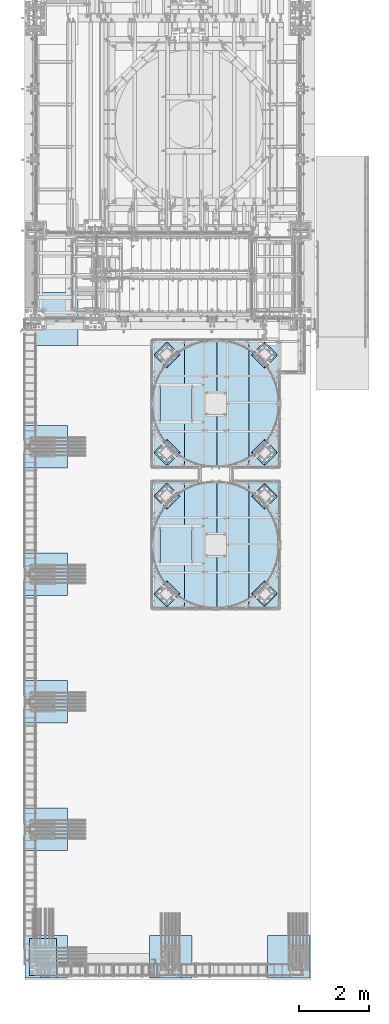
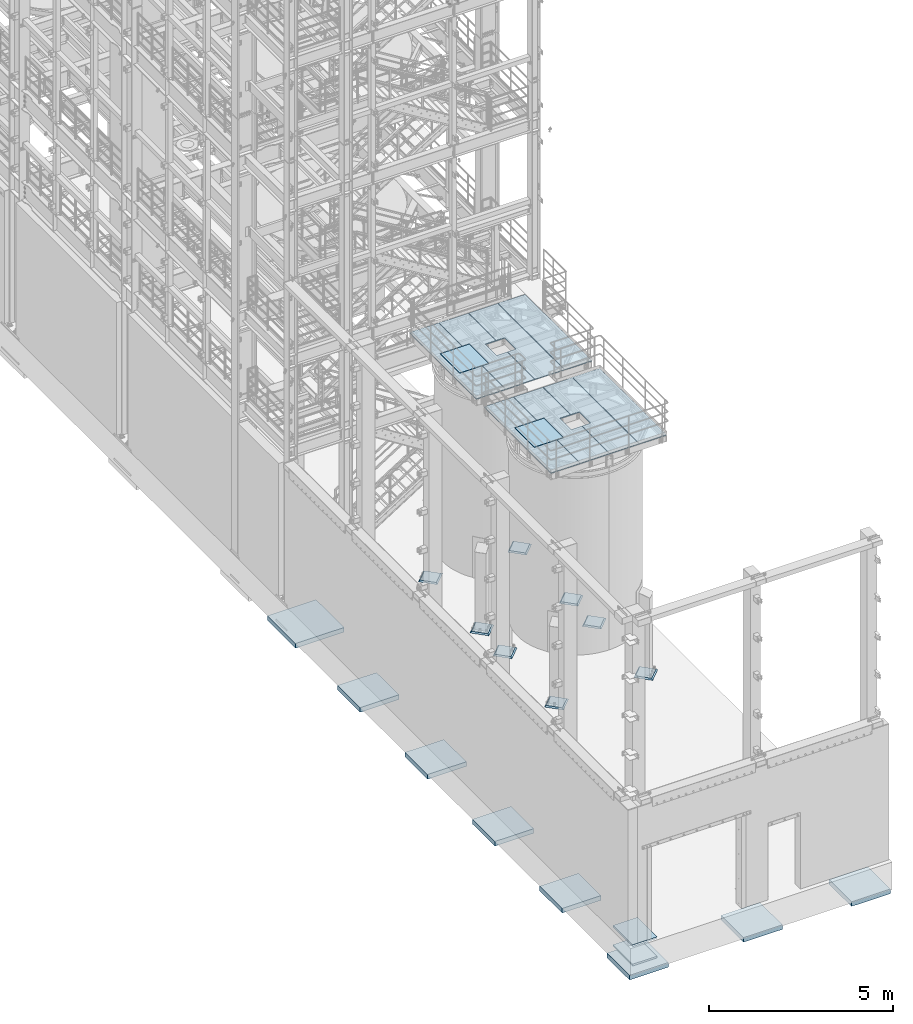
# One storey, part 1401 of 1876: 20 plates, 8 slabs, 27 elements without a shape of their own.
"""IFC2X3 building model written with IfcOpenShell, lengths in millimetres."""

import ifcopenshell
import ifcopenshell.guid

model = None  # the IFC model being written
_history = None  # IfcOwnerHistory: only IFC2X3 demands one
_inside = {}  # id of a spatial element -> (the spatial element, [elements in it])
_under = {}  # id of a project, library or spatial element -> (it, [spatial elements below it])
_declared = {}  # id of a project -> (the project, [libraries it declares])
_typed = {}  # id of a type object -> (the type object, [elements of that type])
_made_of = {}  # id of a material, layer set ... -> (it, [elements and type objects made of it])


def new_model(schema):
    """Start an empty IFC model of exactly this schema.

    Asked for "IFC4X3", IfcOpenShell would pick the latest addendum, in which some entities
    have other attributes; the version numbers below select the first issue.
    IFC2X3 requires an IfcOwnerHistory on every rooted entity: one is made here for all.
    """
    global model, _history
    if schema == "IFC4X3":
        model = ifcopenshell.file(schema_version=(4, 3, 0, 0))
    else:
        model = ifcopenshell.file(schema=schema)
    _inside.clear()
    _under.clear()
    _declared.clear()
    _typed.clear()
    _made_of.clear()
    _history = None
    if model.schema == "IFC2X3":
        org = make("IfcOrganization", Name="unknown")
        user = make(
            "IfcPersonAndOrganization",
            ThePerson=make("IfcPerson", FamilyName="unknown"),
            TheOrganization=org,
        )
        app = make(
            "IfcApplication",
            ApplicationDeveloper=org,
            Version="unknown",
            ApplicationFullName="unknown",
            ApplicationIdentifier="unknown",
        )
        _history = make(
            "IfcOwnerHistory",
            OwningUser=user,
            OwningApplication=app,
            ChangeAction="ADDED",
            CreationDate=0,
        )
    return model


def make(cls, **values):
    """One entity of the class cls with the attributes given. An attribute that is None is left unset."""
    return model.create_entity(
        cls, **{name: value for name, value in values.items() if value is not None}
    )


def rooted(cls, **values):
    """An entity with a GlobalId (a new one), such as an element, a storey or a relation."""
    return make(cls, GlobalId=ifcopenshell.guid.new(), OwnerHistory=_history, **values)


def si_unit(unit_type, name, prefix=None):
    """IfcSIUnit, for example si_unit("LENGTHUNIT", "METRE", prefix="MILLI")."""
    return make("IfcSIUnit", UnitType=unit_type, Prefix=prefix, Name=name)


def assignment(units):
    """IfcUnitAssignment: the units of a project."""
    return None if units is None else make("IfcUnitAssignment", Units=units)


def point(xyz):
    """IfcCartesianPoint."""
    return None if xyz is None else make("IfcCartesianPoint", Coordinates=xyz)


def direction(xyz):
    """IfcDirection."""
    return None if xyz is None else make("IfcDirection", DirectionRatios=xyz)


def frame(location, z_axis=None, x_axis=None):
    """IfcAxis2Placement3D, a coordinate frame: its origin and axes. An axis left out is left unset."""
    return make(
        "IfcAxis2Placement3D",
        Location=point(location),
        Axis=direction(z_axis),
        RefDirection=direction(x_axis),
    )


def origin_with_axes():
    """The frame at (0, 0, 0) with the z axis (0, 0, 1) and the x axis (1, 0, 0) written out."""
    return frame((0.0, 0.0, 0.0), z_axis=(0.0, 0.0, 1.0), x_axis=(1.0, 0.0, 0.0))


def place(relative_to, where):
    """IfcLocalPlacement: puts the frame where relative to a parent placement (None: the world)."""
    return make(
        "IfcLocalPlacement", PlacementRelTo=relative_to, RelativePlacement=where
    )


def context(
    kind, dimensions, precision=None, world=None, true_north=None, identifier=None
):
    """IfcGeometricRepresentationContext, for example the 3D "Model" context."""
    return make(
        "IfcGeometricRepresentationContext",
        ContextIdentifier=identifier,
        ContextType=kind,
        CoordinateSpaceDimension=dimensions,
        Precision=precision,
        WorldCoordinateSystem=world,
        TrueNorth=true_north,
    )


def subcontext(parent, identifier, kind, view, scale=None):
    """IfcGeometricRepresentationSubContext, for example "Body" below "Model"."""
    return make(
        "IfcGeometricRepresentationSubContext",
        ContextIdentifier=identifier,
        ContextType=kind,
        ParentContext=parent,
        TargetScale=scale,
        TargetView=view,
    )


def project(units=None, contexts=None):
    """IfcProject with its units and contexts."""
    return rooted(
        "IfcProject",
        Name="project",
        RepresentationContexts=contexts,
        UnitsInContext=assignment(units),
    )


def spatial(cls, under=None, at=None, **own):
    """A site, building, storey or space (cls), placed at a placement, below another one or the project."""
    s = rooted(cls, ObjectPlacement=at, **own)
    if under is not None:
        _under.setdefault(under.id(), (under, []))[1].append(s)
    return s


def faces_of(points, faces, orient=None, outer=None):
    """IfcFace entities. A face is a list of loops; a loop is a list of indices into points, from 0.

    orient and outer hold one flag for each loop. By default every Orientation is true, the
    first loop of a face is its IfcFaceOuterBound and the others are IfcFaceBound.
    """
    made = []
    for i, loops in enumerate(faces):
        bounds = []
        for j, loop in enumerate(loops):
            is_outer = j == 0 if outer is None else outer[i][j]
            bounds.append(
                make(
                    "IfcFaceOuterBound" if is_outer else "IfcFaceBound",
                    Bound=make("IfcPolyLoop", Polygon=[points[k] for k in loop]),
                    Orientation=True if orient is None else orient[i][j],
                )
            )
        made.append(make("IfcFace", Bounds=bounds))
    return made


def faceted_brep(points, faces, orient=None, outer=None, voids=None):
    """IfcFacetedBrep: a solid bounded by flat faces; with voids (closed shells), ...WithVoids."""
    shared = [point(p) for p in points]
    hull = make("IfcClosedShell", CfsFaces=faces_of(shared, faces, orient, outer))
    if voids is None:
        return make("IfcFacetedBrep", Outer=hull)
    return make(
        "IfcFacetedBrepWithVoids",
        Outer=hull,
        Voids=[
            make(cls, CfsFaces=faces_of(shared, fs, o, b)) for cls, fs, o, b in voids
        ],
    )


def shape(context_of_items, identifier, shape_type, items):
    """IfcShapeRepresentation: the items that make up one representation, for example the "Body"."""
    return make(
        "IfcShapeRepresentation",
        ContextOfItems=context_of_items,
        RepresentationIdentifier=identifier,
        RepresentationType=shape_type,
        Items=items,
    )


def material(Name=None, Category=None):
    """IfcMaterial."""
    return make("IfcMaterial", Name=Name, Category=Category)


def made_of(thing, what):
    """Note that an element or type object is made of a material, layer set ...; save() writes the relation."""
    if what is not None:
        _made_of.setdefault(what.id(), (what, []))[1].append(thing)
    return thing


def type_object(cls, material=None, **own):
    """A type object (cls), such as IfcWallType, which elements share."""
    return made_of(rooted(cls, **own), material)


def element(
    cls,
    number,
    at=None,
    inside=None,
    cuts=None,
    type_object=None,
    material=None,
    context=None,
    identifier="Body",
    shape_type=None,
    held_by="IfcProductDefinitionShape",
    body=None,
    shapes=None,
    **own,
):
    """One element of the class cls, such as IfcWall. Its Tag is "e" and its number.

    at: its placement. inside: the storey or other place that contains it. cuts: it is an
    opening in that element (IfcRelVoidsElement). A single representation is given by context,
    identifier, shape_type and body (its items); several are given by shapes. held_by: the class
    of the entity that holds the representations. save() writes the other relations.
    """
    e = rooted(cls, Tag="e%d" % number, ObjectPlacement=at, **own)
    if body is not None:
        shapes = [shape(context, identifier, shape_type, body)]
    if shapes is not None:
        e.Representation = make(held_by, Representations=shapes)
    if inside is not None:
        _inside.setdefault(inside.id(), (inside, []))[1].append(e)
    if cuts is not None:
        rooted(
            "IfcRelVoidsElement", RelatingBuildingElement=cuts, RelatedOpeningElement=e
        )
    if type_object is not None:
        _typed.setdefault(type_object.id(), (type_object, []))[1].append(e)
    return made_of(e, material)


def aggregate(whole, parts):
    """IfcRelAggregates: a whole, such as a stair, and the parts it consists of."""
    return rooted("IfcRelAggregates", RelatingObject=whole, RelatedObjects=parts)


def save(model, path):
    """Write the relations noted so far, then the file.

    IfcRelAggregates (storeys below a building ...), IfcRelContainedInSpatialStructure (elements
    in a storey), IfcRelDefinesByType, IfcRelAssociatesMaterial and IfcRelDeclares: one each for
    every whole, place, type object, material and project.
    """
    for whole, parts in _under.values():
        aggregate(whole, parts)
    for where, things in _inside.values():
        rooted(
            "IfcRelContainedInSpatialStructure",
            RelatedElements=things,
            RelatingStructure=where,
        )
    for kind, things in _typed.values():
        rooted("IfcRelDefinesByType", RelatedObjects=things, RelatingType=kind)
    for what, things in _made_of.values():
        rooted("IfcRelAssociatesMaterial", RelatedObjects=things, RelatingMaterial=what)
    for by, libraries in _declared.values():
        rooted("IfcRelDeclares", RelatingContext=by, RelatedDefinitions=libraries)
    model.write(path)


model = new_model("IFC2X3")

# Units and contexts
model_context = context("Model", 3, precision=1e-05, world=origin_with_axes())
body_context = subcontext(model_context, "Body", "Model", "MODEL_VIEW")
ifc_project = project(units=[si_unit("LENGTHUNIT", "METRE", prefix="MILLI"), si_unit("AREAUNIT", "SQUARE_METRE"), si_unit("VOLUMEUNIT", "CUBIC_METRE"), si_unit("MASSUNIT", "GRAM", prefix="KILO"), si_unit("TIMEUNIT", "SECOND"), si_unit("PLANEANGLEUNIT", "RADIAN"), si_unit("SOLIDANGLEUNIT", "STERADIAN"), si_unit("THERMODYNAMICTEMPERATUREUNIT", "DEGREE_CELSIUS"), si_unit("LUMINOUSINTENSITYUNIT", "LUMEN")], contexts=[model_context])

# Site, building, storey
site_placement = place(None, origin_with_axes())
site = spatial("IfcSite", under=ifc_project, at=site_placement, CompositionType="ELEMENT")
building_placement = place(site_placement, origin_with_axes())
building = spatial("IfcBuilding", under=site, at=building_placement, Name="Undefined", CompositionType="ELEMENT")
storey_placement = place(building_placement, origin_with_axes())
storey = spatial("IfcBuildingStorey", under=building, at=storey_placement, Name="Undefined", CompositionType="ELEMENT", Elevation=0.0)

# Assembly, plate
assembly_1_placement = place(storey_placement, origin_with_axes())
assembly_1 = element("IfcElementAssembly", 1, at=assembly_1_placement, inside=storey, Name="GRATING", AssemblyPlace="NOTDEFINED", PredefinedType="NOTDEFINED")
ifc_material_1 = material(Name="1")
plate_type_1 = type_object("IfcPlateType", PredefinedType="NOTDEFINED")
plate_1_placement = place(assembly_1_placement, frame((4294.19438669416, -7727.85504150392, 8010.525), z_axis=(1.0, 0.0, 0.0), x_axis=(0.0, -1.0, 0.0)))
plate_1 = element("IfcPlate", 2, at=plate_1_placement, type_object=plate_type_1, material=ifc_material_1, Name="GRATING", context=body_context, shape_type="Brep", body=[
    faceted_brep([(1505.00936279233, -12.6999999999998, 909.637451171875), (1505.00936279233, -12.6999999999998, 582.6103515625), (1505.00936279233, 12.6999999999998, 582.6103515625), (1505.00936279233, 12.6999999999998, 909.637451171875), (2114.60933837827, -12.6999999999998, 582.6103515625), (2114.60933837827, 12.6999999999998, 582.6103515625), (2114.60933837827, -12.6999999999998, 909.637451171875), (2114.60933837827, 12.6999999999998, 909.637451171875), (0.0, -12.6999999999998, 0.0), (0.0, -12.6999999999998, 909.637451171875), (0.0, 12.6999999999998, 909.637451171875), (0.0, 12.6999999999998, 0.0), (1273.23428955075, 12.6999999999998, 0.0), (1273.23428955075, -12.6999999999998, 0.0), (1273.23428955075, 12.6999999999998, 214.310363769531), (1273.23428955075, -12.6999999999998, 214.310363769531), (2346.38431396481, 12.6999999999998, 214.310363769531), (2346.38431396481, -12.6999999999998, 214.310363769531), (2346.38431396481, 12.6999999999998, 0.0), (2346.38431396481, -12.6999999999998, 0.0), (3619.5029296875, 12.6999999999998, 0.0), (3619.5029296875, -12.6999999999998, 0.0), (3619.5029296875, -12.6999999999998, 909.637451171875), (3619.5029296875, 12.6999999999998, 909.637451171875)], [[[0, 1, 2, 3]], [[4, 5, 2, 1]], [[6, 7, 5, 4]], [[8, 9, 10, 11]], [[8, 11, 12, 13]], [[13, 12, 14, 15]], [[15, 14, 16, 17]], [[17, 16, 18, 19]], [[20, 21, 19, 18]], [[22, 21, 20, 23]], [[1, 0, 9, 8, 13, 15, 17, 19, 21, 22, 6, 4]], [[10, 9, 0, 3]], [[23, 20, 18, 16, 14, 12, 11, 10, 3, 2, 5, 7]], [[22, 23, 7, 6]]]),
])
aggregate(assembly_1, [plate_1])

assembly_2_placement = place(storey_placement, origin_with_axes())
assembly_2 = element("IfcElementAssembly", 3, at=assembly_2_placement, inside=storey, Name="GRATING", AssemblyPlace="NOTDEFINED", PredefinedType="NOTDEFINED")
plate_2_placement = place(assembly_2_placement, frame((4502.15642282698, -9007.43935546873, 8010.525), z_axis=(0.0, -1.0, 0.0), x_axis=(-1.0, 0.0, 0.0)))
plate_2 = element("IfcPlate", 4, at=plate_2_placement, type_object=plate_type_1, material=ifc_material_1, Name="GRATING", context=body_context, shape_type="Brep", body=[
    faceted_brep([(0.0, -12.6999999999998, 0.0), (0.0, -12.6999999999998, 1060.45007324219), (0.0, 12.6999999999998, 1060.45007324219), (0.0, 12.6999999999998, 0.0), (909.637512207031, -12.6999999999998, 1060.45007324219), (909.637512207031, 12.6999999999998, 1060.45007324219), (909.637512207031, -12.6999999999998, 0.0), (909.637512207031, 12.6999999999998, 0.0)], [[[0, 1, 2, 3]], [[1, 4, 5, 2]], [[4, 6, 7, 5]], [[6, 0, 3, 7]], [[5, 7, 3, 2]], [[6, 4, 1, 0]]]),
])
aggregate(assembly_2, [plate_2])

assembly_3_placement = place(storey_placement, origin_with_axes())
assembly_3 = element("IfcElementAssembly", 5, at=assembly_3_placement, inside=storey, Name="GRATING", AssemblyPlace="NOTDEFINED", PredefinedType="NOTDEFINED")
plate_3_placement = place(assembly_3_placement, frame((6126.19981080997, -7727.91440629959, 8010.525), z_axis=(0.0, -1.0, 0.0), x_axis=(-1.0, 0.0, 0.0)))
plate_3 = element("IfcPlate", 6, at=plate_3_placement, type_object=plate_type_1, material=ifc_material_1, Name="GRATING", context=body_context, shape_type="Brep", body=[
    faceted_brep([(909.650556084588, -12.6999999999998, 1504.89205319779), (909.650556084588, 12.6999999999998, 1504.89205319779), (639.795063440009, 12.6999999999998, 1504.89205249954), (639.795063440009, -12.6999999999998, 1504.89205249954), (639.795062220694, 12.6999999999998, 2114.54995044876), (639.795062220694, -12.6999999999998, 2114.54995044876), (909.655820145314, -12.6999999999998, 2114.54763165254), (909.655840365745, 12.6999999999998, 2114.54763165237), (909.637512207031, -12.6999999999998, 0.0), (0.0, -12.6999999999998, 0.0), (0.0, 12.6999999999998, 0.0), (909.637512207031, 12.6999999999998, 0.0), (0.0313640496860899, -12.6999999999998, 3619.44360351562), (0.0313640496860899, 12.6999999999998, 3619.44360351562), (909.668884277267, -12.6999999999998, 3619.44360351565), (909.668884277267, 12.6999999999998, 3619.44360351565)], [[[0, 1, 2, 3]], [[3, 2, 4, 5]], [[6, 5, 4, 7]], [[8, 9, 10, 11]], [[9, 12, 13, 10]], [[12, 14, 15, 13]], [[15, 14, 6, 7]], [[2, 1, 11, 10, 13, 15, 7, 4]], [[8, 11, 1, 0]], [[14, 12, 9, 8, 0, 3, 5, 6]]]),
])
aggregate(assembly_3, [plate_3])

assembly_4_placement = place(storey_placement, origin_with_axes())
assembly_4 = element("IfcElementAssembly", 7, at=assembly_4_placement, inside=storey, Name="GRATING", AssemblyPlace="NOTDEFINED", PredefinedType="NOTDEFINED")
plate_4_placement = place(assembly_4_placement, frame((4281.49144479963, -7727.85498046876, 8010.525), z_axis=(0.0, -1.0, 0.0), x_axis=(-1.0, 0.0, 0.0)))
plate_4 = element("IfcPlate", 8, at=plate_4_placement, type_object=plate_type_1, material=ifc_material_1, Name="GRATING", context=body_context, shape_type="Brep", body=[
    faceted_brep([(700.086669921875, -12.6999999999998, 1273.17810058594), (700.086669921875, 12.6999999999998, 1273.17810058594), (-6.09361450187862e-11, 12.6999999999998, 1273.17810058594), (-6.09361450187862e-11, -12.6999999999998, 1273.17810058594), (700.086669921875, -12.6999999999998, 2346.32873535156), (700.086669921875, 12.6999999999998, 2346.32873535156), (-1.12777343019843e-10, -12.6999999999998, 2346.32873535156), (-1.12777343019843e-10, 12.6999999999998, 2346.32873535156), (-1.73713488038629e-10, -12.6999999999998, 3619.5029296875), (909.637451171875, -12.6999999999998, 3619.5029296875), (909.637451171875, 12.6999999999998, 3619.5029296875), (-1.73713488038629e-10, 12.6999999999998, 3619.5029296875), (909.606201171875, -12.6999999999998, 0.0), (909.606201171875, 12.6999999999998, 0.0), (0.0, -12.6999999999998, 0.0), (0.0, 12.6999999999998, 0.0)], [[[0, 1, 2, 3]], [[4, 5, 1, 0]], [[6, 7, 5, 4]], [[8, 9, 10, 11]], [[9, 12, 13, 10]], [[12, 14, 15, 13]], [[15, 14, 3, 2]], [[11, 10, 13, 15, 2, 1, 5, 7]], [[8, 11, 7, 6]], [[3, 14, 12, 9, 8, 6, 4, 0]]]),
])
aggregate(assembly_4, [plate_4])

assembly_5_placement = place(storey_placement, origin_with_axes())
assembly_5 = element("IfcElementAssembly", 9, at=assembly_5_placement, inside=storey, Name="GRATING", AssemblyPlace="NOTDEFINED", PredefinedType="NOTDEFINED")
plate_5_placement = place(assembly_5_placement, frame((4294.19107225776, -11779.155090332, 8010.525), z_axis=(1.0, 0.0, 0.0), x_axis=(0.0, -1.0, 0.0)))
plate_5 = element("IfcPlate", 10, at=plate_5_placement, type_object=plate_type_1, material=ifc_material_1, Name="GRATING", context=body_context, shape_type="Brep", body=[
    faceted_brep([(1505.00936279233, -12.6999999999998, 909.637451171875), (1505.00936279233, -12.6999999999998, 582.6103515625), (1505.00936279233, 12.6999999999998, 582.6103515625), (1505.00936279233, 12.6999999999998, 909.637451171875), (2114.60933837827, -12.6999999999998, 582.6103515625), (2114.60933837827, 12.6999999999998, 582.6103515625), (2114.60933837827, -12.6999999999998, 909.637451171875), (2114.60933837827, 12.6999999999998, 909.637451171875), (0.0, -12.6999999999998, 0.0), (0.0, -12.6999999999998, 909.637451171875), (0.0, 12.6999999999998, 909.637451171875), (0.0, 12.6999999999998, 0.0), (1273.23428955075, 12.6999999999998, 0.0), (1273.23428955075, -12.6999999999998, 0.0), (1273.23428955075, 12.6999999999998, 214.310363769531), (1273.23428955075, -12.6999999999998, 214.310363769531), (2346.38431396481, 12.6999999999998, 214.310363769531), (2346.38431396481, -12.6999999999998, 214.310363769531), (2346.38431396481, 12.6999999999998, 0.0), (2346.38431396481, -12.6999999999998, 0.0), (3619.5029296875, 12.6999999999998, 0.0), (3619.5029296875, -12.6999999999998, 0.0), (3619.5029296875, -12.6999999999998, 909.637451171875), (3619.5029296875, 12.6999999999998, 909.637451171875)], [[[0, 1, 2, 3]], [[4, 5, 2, 1]], [[6, 7, 5, 4]], [[8, 9, 10, 11]], [[8, 11, 12, 13]], [[13, 12, 14, 15]], [[15, 14, 16, 17]], [[17, 16, 18, 19]], [[20, 21, 19, 18]], [[22, 21, 20, 23]], [[1, 0, 9, 8, 13, 15, 17, 19, 21, 22, 6, 4]], [[10, 9, 0, 3]], [[23, 20, 18, 16, 14, 12, 11, 10, 3, 2, 5, 7]], [[22, 23, 7, 6]]]),
])
aggregate(assembly_5, [plate_5])

assembly_6_placement = place(storey_placement, origin_with_axes())
assembly_6 = element("IfcElementAssembly", 11, at=assembly_6_placement, inside=storey, Name="GRATING", AssemblyPlace="NOTDEFINED", PredefinedType="NOTDEFINED")
plate_6_placement = place(assembly_6_placement, frame((4502.15310839057, -13058.7394042969, 8010.525), z_axis=(0.0, -1.0, 0.0), x_axis=(-1.0, 0.0, 0.0)))
plate_6 = element("IfcPlate", 12, at=plate_6_placement, type_object=plate_type_1, material=ifc_material_1, Name="GRATING", context=body_context, shape_type="Brep", body=[
    faceted_brep([(0.0, -12.6999999999998, 0.0), (0.0, -12.6999999999998, 1060.45007324219), (0.0, 12.6999999999998, 1060.45007324219), (0.0, 12.6999999999998, 0.0), (909.637512207031, -12.6999999999998, 1060.45007324219), (909.637512207031, 12.6999999999998, 1060.45007324219), (909.637512207031, -12.6999999999998, 0.0), (909.637512207031, 12.6999999999998, 0.0)], [[[0, 1, 2, 3]], [[1, 4, 5, 2]], [[4, 6, 7, 5]], [[6, 0, 3, 7]], [[5, 7, 3, 2]], [[6, 4, 1, 0]]]),
])
aggregate(assembly_6, [plate_6])

assembly_7_placement = place(storey_placement, origin_with_axes())
assembly_7 = element("IfcElementAssembly", 13, at=assembly_7_placement, inside=storey, Name="GRATING", AssemblyPlace="NOTDEFINED", PredefinedType="NOTDEFINED")
plate_7_placement = place(assembly_7_placement, frame((6126.19649637357, -11779.2144551277, 8010.525), z_axis=(0.0, -1.0, 0.0), x_axis=(-1.0, 0.0, 0.0)))
plate_7 = element("IfcPlate", 14, at=plate_7_placement, type_object=plate_type_1, material=ifc_material_1, Name="GRATING", context=body_context, shape_type="Brep", body=[
    faceted_brep([(909.650556084588, -12.6999999999998, 1504.89205319779), (909.650556084588, 12.6999999999998, 1504.89205319779), (639.795063440009, 12.6999999999998, 1504.89205249954), (639.795063440009, -12.6999999999998, 1504.89205249954), (639.795062220694, 12.6999999999998, 2114.54995044876), (639.795062220694, -12.6999999999998, 2114.54995044876), (909.655820145314, -12.6999999999998, 2114.54763165254), (909.655840365745, 12.6999999999998, 2114.54763165237), (909.637512207031, -12.6999999999998, 0.0), (0.0, -12.6999999999998, 0.0), (0.0, 12.6999999999998, 0.0), (909.637512207031, 12.6999999999998, 0.0), (0.0313640496860899, -12.6999999999998, 3619.44360351562), (0.0313640496860899, 12.6999999999998, 3619.44360351562), (909.668884277267, -12.6999999999998, 3619.44360351565), (909.668884277267, 12.6999999999998, 3619.44360351565)], [[[0, 1, 2, 3]], [[3, 2, 4, 5]], [[6, 5, 4, 7]], [[8, 9, 10, 11]], [[9, 12, 13, 10]], [[12, 14, 15, 13]], [[15, 14, 6, 7]], [[2, 1, 11, 10, 13, 15, 7, 4]], [[8, 11, 1, 0]], [[14, 12, 9, 8, 0, 3, 5, 6]]]),
])
aggregate(assembly_7, [plate_7])

assembly_8_placement = place(storey_placement, origin_with_axes())
assembly_8 = element("IfcElementAssembly", 15, at=assembly_8_placement, inside=storey, Name="GRATING", AssemblyPlace="NOTDEFINED", PredefinedType="NOTDEFINED")
plate_8_placement = place(assembly_8_placement, frame((4281.48813036323, -11779.1550292969, 8010.525), z_axis=(0.0, -1.0, 0.0), x_axis=(-1.0, 0.0, 0.0)))
plate_8 = element("IfcPlate", 16, at=plate_8_placement, type_object=plate_type_1, material=ifc_material_1, Name="GRATING", context=body_context, shape_type="Brep", body=[
    faceted_brep([(700.086669921875, -12.6999999999998, 1273.17810058594), (700.086669921875, 12.6999999999998, 1273.17810058594), (-6.09361450187862e-11, 12.6999999999998, 1273.17810058594), (-6.09361450187862e-11, -12.6999999999998, 1273.17810058594), (700.086669921875, -12.6999999999998, 2346.32873535156), (700.086669921875, 12.6999999999998, 2346.32873535156), (-1.12777343019843e-10, -12.6999999999998, 2346.32873535156), (-1.12777343019843e-10, 12.6999999999998, 2346.32873535156), (-1.73713488038629e-10, -12.6999999999998, 3619.5029296875), (909.637451171875, -12.6999999999998, 3619.5029296875), (909.637451171875, 12.6999999999998, 3619.5029296875), (-1.73713488038629e-10, 12.6999999999998, 3619.5029296875), (909.606201171875, -12.6999999999998, 0.0), (909.606201171875, 12.6999999999998, 0.0), (0.0, -12.6999999999998, 0.0), (0.0, 12.6999999999998, 0.0)], [[[0, 1, 2, 3]], [[4, 5, 1, 0]], [[6, 7, 5, 4]], [[8, 9, 10, 11]], [[9, 12, 13, 10]], [[12, 14, 15, 13]], [[15, 14, 3, 2]], [[11, 10, 13, 15, 2, 1, 5, 7]], [[8, 11, 7, 6]], [[3, 14, 12, 9, 8, 6, 4, 0]]]),
])
aggregate(assembly_8, [plate_8])

assembly_9_placement = place(storey_placement, origin_with_axes())
assembly_9 = element("IfcElementAssembly", 17, at=assembly_9_placement, inside=storey, Name="GRATING", AssemblyPlace="NOTDEFINED", PredefinedType="NOTDEFINED")
plate_type_2 = type_object("IfcPlateType", PredefinedType="NOTDEFINED")
plate_9_placement = place(assembly_9_placement, frame((6991.35188293519, -7727.91439819337, 8010.525), z_axis=(0.0, -1.0, 0.0), x_axis=(-1.0, 0.0, 0.0)))
plate_9 = element("IfcPlate", 18, at=plate_9_placement, type_object=plate_type_2, material=ifc_material_1, Name="GRATING", context=body_context, shape_type="Brep", body=[
    faceted_brep([(0.0, -12.6999999999998, 0.0), (-0.000154892113641836, -12.6999999999998, 3619.44360351563), (-0.000154892113641836, 12.6999999999998, 3619.44360351563), (0.0, 12.6999999999998, 0.0), (849.30828857422, -12.6999999999998, 3619.44360351563), (849.30828857422, 12.6999999999998, 3619.44360351563), (849.277099609376, -12.6999999999998, 2.89219315163791e-10), (849.277099609376, 12.6999999999998, 2.89219315163791e-10)], [[[0, 1, 2, 3]], [[1, 4, 5, 2]], [[4, 6, 7, 5]], [[6, 0, 3, 7]], [[5, 7, 3, 2]], [[6, 4, 1, 0]]]),
])
aggregate(assembly_9, [plate_9])

assembly_10_placement = place(storey_placement, origin_with_axes())
assembly_10 = element("IfcElementAssembly", 19, at=assembly_10_placement, inside=storey, Name="GRATING", AssemblyPlace="NOTDEFINED", PredefinedType="NOTDEFINED")
plate_10_placement = place(assembly_10_placement, frame((6991.34856849878, -11779.2144470215, 8010.525), z_axis=(0.0, -1.0, 0.0), x_axis=(-1.0, 0.0, 0.0)))
plate_10 = element("IfcPlate", 20, at=plate_10_placement, type_object=plate_type_2, material=ifc_material_1, Name="GRATING", context=body_context, shape_type="Brep", body=[
    faceted_brep([(0.0, -12.6999999999998, 0.0), (-0.000154892113641836, -12.6999999999998, 3619.44360351563), (-0.000154892113641836, 12.6999999999998, 3619.44360351563), (0.0, 12.6999999999998, 0.0), (849.30828857422, -12.6999999999998, 3619.44360351563), (849.30828857422, 12.6999999999998, 3619.44360351563), (849.277099609376, -12.6999999999998, 2.89219315163791e-10), (849.277099609376, 12.6999999999998, 2.89219315163791e-10)], [[[0, 1, 2, 3]], [[1, 4, 5, 2]], [[4, 6, 7, 5]], [[6, 0, 3, 7]], [[5, 7, 3, 2]], [[6, 4, 1, 0]]]),
])
aggregate(assembly_10, [plate_10])

assembly_11_placement = place(storey_placement, origin_with_axes())
assembly_11 = element("IfcElementAssembly", 21, at=assembly_11_placement, inside=storey, Name="GROUT", AssemblyPlace="NOTDEFINED", PredefinedType="REINFORCEMENT_UNIT")
ifc_material_2 = material(Name="CONCRETE/Concrete_Undefined")
plate_type_3 = type_object("IfcPlateType", PredefinedType="NOTDEFINED")
plate_11_placement = place(assembly_11_placement, frame((6580.27489085653, -15364.7031474952, 19.05), z_axis=(-0.707106781186548, 0.707106781186547, 0.0), x_axis=(0.707106781186548, 0.707106781186547, 0.0)))
plate_11 = element("IfcPlate", 22, at=plate_11_placement, type_object=plate_type_3, material=ifc_material_2, Name="GROUT", context=body_context, shape_type="Brep", body=[
    faceted_brep([(38.100000011611, -19.05, 495.299999988873), (-2.72848410531878e-12, 19.05, 533.400024414152), (-9.09494701772928e-13, 19.05, -1.81898940354586e-12), (38.1000000120275, -19.05, 38.1000000109725), (495.299999989061, -19.05, 38.1000000105578), (533.40002441415, 19.05, -1.81898940354586e-12), (533.400024414151, 19.05, 533.400024414152), (495.299999989063, -19.05, 495.299999988873)], [[[0, 1, 2, 3]], [[4, 5, 6, 7]], [[4, 7, 0, 3]], [[5, 4, 3, 2]], [[6, 5, 2, 1]], [[7, 6, 1, 0]]]),
])
aggregate(assembly_11, [plate_11])

assembly_12_placement = place(storey_placement, origin_with_axes())
assembly_12 = element("IfcElementAssembly", 23, at=assembly_12_placement, inside=storey, Name="GROUT", AssemblyPlace="NOTDEFINED", PredefinedType="REINFORCEMENT_UNIT")
plate_12_placement = place(assembly_12_placement, frame((6580.27489085653, -12567.4958662285, 19.05), z_axis=(-0.707106781186548, 0.707106781186547, 0.0), x_axis=(0.707106781186548, 0.707106781186547, 0.0)))
plate_12 = element("IfcPlate", 24, at=plate_12_placement, type_object=plate_type_3, material=ifc_material_2, Name="GROUT", context=body_context, shape_type="Brep", body=[
    faceted_brep([(38.100000011611, -19.05, 495.299999988873), (-2.72848410531878e-12, 19.05, 533.400024414152), (-9.09494701772928e-13, 19.05, -1.81898940354586e-12), (38.1000000120275, -19.05, 38.1000000109725), (495.299999989061, -19.05, 38.1000000105578), (533.40002441415, 19.05, -1.81898940354586e-12), (533.400024414151, 19.05, 533.400024414152), (495.299999989063, -19.05, 495.299999988873)], [[[0, 1, 2, 3]], [[4, 5, 6, 7]], [[4, 7, 0, 3]], [[5, 4, 3, 2]], [[6, 5, 2, 1]], [[7, 6, 1, 0]]]),
])
aggregate(assembly_12, [plate_12])

assembly_13_placement = place(storey_placement, origin_with_axes())
assembly_13 = element("IfcElementAssembly", 25, at=assembly_13_placement, inside=storey, Name="GROUT", AssemblyPlace="NOTDEFINED", PredefinedType="REINFORCEMENT_UNIT")
plate_13_placement = place(assembly_13_placement, frame((6580.27820529291, -11313.4031474952, 19.05), z_axis=(-0.707106781186548, 0.707106781186547, 0.0), x_axis=(0.707106781186548, 0.707106781186547, 0.0)))
plate_13 = element("IfcPlate", 26, at=plate_13_placement, type_object=plate_type_3, material=ifc_material_2, Name="GROUT", context=body_context, shape_type="Brep", body=[
    faceted_brep([(38.100000011611, -19.05, 495.299999988873), (-2.72848410531878e-12, 19.05, 533.400024414152), (-9.09494701772928e-13, 19.05, -1.81898940354586e-12), (38.1000000120275, -19.05, 38.1000000109725), (495.299999989061, -19.05, 38.1000000105578), (533.40002441415, 19.05, -1.81898940354586e-12), (533.400024414151, 19.05, 533.400024414152), (495.299999989063, -19.05, 495.299999988873)], [[[0, 1, 2, 3]], [[4, 5, 6, 7]], [[4, 7, 0, 3]], [[5, 4, 3, 2]], [[6, 5, 2, 1]], [[7, 6, 1, 0]]]),
])
aggregate(assembly_13, [plate_13])

assembly_14_placement = place(storey_placement, origin_with_axes())
assembly_14 = element("IfcElementAssembly", 27, at=assembly_14_placement, inside=storey, Name="GROUT", AssemblyPlace="NOTDEFINED", PredefinedType="REINFORCEMENT_UNIT")
plate_14_placement = place(assembly_14_placement, frame((6580.27820529291, -8516.19586622847, 19.05), z_axis=(-0.707106781186548, 0.707106781186547, 0.0), x_axis=(0.707106781186548, 0.707106781186547, 0.0)))
plate_14 = element("IfcPlate", 28, at=plate_14_placement, type_object=plate_type_3, material=ifc_material_2, Name="GROUT", context=body_context, shape_type="Brep", body=[
    faceted_brep([(38.100000011611, -19.05, 495.299999988873), (-2.72848410531878e-12, 19.05, 533.400024414152), (-9.09494701772928e-13, 19.05, -1.81898940354586e-12), (38.1000000120275, -19.05, 38.1000000109725), (495.299999989061, -19.05, 38.1000000105578), (533.40002441415, 19.05, -1.81898940354586e-12), (533.400024414151, 19.05, 533.400024414152), (495.299999989063, -19.05, 495.299999988873)], [[[0, 1, 2, 3]], [[4, 5, 6, 7]], [[4, 7, 0, 3]], [[5, 4, 3, 2]], [[6, 5, 2, 1]], [[7, 6, 1, 0]]]),
])
aggregate(assembly_14, [plate_14])

assembly_15_placement = place(storey_placement, origin_with_axes())
assembly_15 = element("IfcElementAssembly", 29, at=assembly_15_placement, inside=storey, Name="GROUT", AssemblyPlace="NOTDEFINED", PredefinedType="REINFORCEMENT_UNIT")
plate_15_placement = place(assembly_15_placement, frame((3783.01619380156, -8516.14113600386, 19.05), z_axis=(-0.707106781186548, 0.707106781186547, 0.0), x_axis=(0.707106781186548, 0.707106781186547, 0.0)))
plate_15 = element("IfcPlate", 30, at=plate_15_placement, type_object=plate_type_3, material=ifc_material_2, Name="GROUT", context=body_context, shape_type="Brep", body=[
    faceted_brep([(38.100000011611, -19.05, 495.299999988873), (-2.72848410531878e-12, 19.05, 533.400024414152), (-9.09494701772928e-13, 19.05, -1.81898940354586e-12), (38.1000000120275, -19.05, 38.1000000109725), (495.299999989061, -19.05, 38.1000000105578), (533.40002441415, 19.05, -1.81898940354586e-12), (533.400024414151, 19.05, 533.400024414152), (495.299999989063, -19.05, 495.299999988873)], [[[0, 1, 2, 3]], [[4, 5, 6, 7]], [[4, 7, 0, 3]], [[5, 4, 3, 2]], [[6, 5, 2, 1]], [[7, 6, 1, 0]]]),
])
aggregate(assembly_15, [plate_15])

assembly_16_placement = place(storey_placement, origin_with_axes())
assembly_16 = element("IfcElementAssembly", 31, at=assembly_16_placement, inside=storey, Name="GROUT", AssemblyPlace="NOTDEFINED", PredefinedType="REINFORCEMENT_UNIT")
plate_16_placement = place(assembly_16_placement, frame((3782.92548850865, -11313.5485830127, 19.05), z_axis=(-0.707106781186548, 0.707106781186547, 0.0), x_axis=(0.707106781186548, 0.707106781186547, 0.0)))
plate_16 = element("IfcPlate", 32, at=plate_16_placement, type_object=plate_type_3, material=ifc_material_2, Name="GROUT", context=body_context, shape_type="Brep", body=[
    faceted_brep([(38.100000011611, -19.05, 495.299999988873), (-2.72848410531878e-12, 19.05, 533.400024414152), (-9.09494701772928e-13, 19.05, -1.81898940354586e-12), (38.1000000120275, -19.05, 38.1000000109725), (495.299999989061, -19.05, 38.1000000105578), (533.40002441415, 19.05, -1.81898940354586e-12), (533.400024414151, 19.05, 533.400024414152), (495.299999989063, -19.05, 495.299999988873)], [[[0, 1, 2, 3]], [[4, 5, 6, 7]], [[4, 7, 0, 3]], [[5, 4, 3, 2]], [[6, 5, 2, 1]], [[7, 6, 1, 0]]]),
])
aggregate(assembly_16, [plate_16])

assembly_17_placement = place(storey_placement, origin_with_axes())
assembly_17 = element("IfcElementAssembly", 33, at=assembly_17_placement, inside=storey, Name="GROUT", AssemblyPlace="NOTDEFINED", PredefinedType="REINFORCEMENT_UNIT")
plate_17_placement = place(assembly_17_placement, frame((3783.01287936518, -12567.4411360039, 19.05), z_axis=(-0.707106781186548, 0.707106781186547, 0.0), x_axis=(0.707106781186548, 0.707106781186547, 0.0)))
plate_17 = element("IfcPlate", 34, at=plate_17_placement, type_object=plate_type_3, material=ifc_material_2, Name="GROUT", context=body_context, shape_type="Brep", body=[
    faceted_brep([(38.100000011611, -19.05, 495.299999988873), (-2.72848410531878e-12, 19.05, 533.400024414152), (-9.09494701772928e-13, 19.05, -1.81898940354586e-12), (38.1000000120275, -19.05, 38.1000000109725), (495.299999989061, -19.05, 38.1000000105578), (533.40002441415, 19.05, -1.81898940354586e-12), (533.400024414151, 19.05, 533.400024414152), (495.299999989063, -19.05, 495.299999988873)], [[[0, 1, 2, 3]], [[4, 5, 6, 7]], [[4, 7, 0, 3]], [[5, 4, 3, 2]], [[6, 5, 2, 1]], [[7, 6, 1, 0]]]),
])
aggregate(assembly_17, [plate_17])

assembly_18_placement = place(storey_placement, origin_with_axes())
assembly_18 = element("IfcElementAssembly", 35, at=assembly_18_placement, inside=storey, Name="GROUT", AssemblyPlace="NOTDEFINED", PredefinedType="REINFORCEMENT_UNIT")
plate_18_placement = place(assembly_18_placement, frame((3782.92217407227, -15364.8485830127, 19.05), z_axis=(-0.707106781186548, 0.707106781186547, 0.0), x_axis=(0.707106781186548, 0.707106781186547, 0.0)))
plate_18 = element("IfcPlate", 36, at=plate_18_placement, type_object=plate_type_3, material=ifc_material_2, Name="GROUT", context=body_context, shape_type="Brep", body=[
    faceted_brep([(38.100000011611, -19.05, 495.299999988873), (-2.72848410531878e-12, 19.05, 533.400024414152), (-9.09494701772928e-13, 19.05, -1.81898940354586e-12), (38.1000000120275, -19.05, 38.1000000109725), (495.299999989061, -19.05, 38.1000000105578), (533.40002441415, 19.05, -1.81898940354586e-12), (533.400024414151, 19.05, 533.400024414152), (495.299999989063, -19.05, 495.299999988873)], [[[0, 1, 2, 3]], [[4, 5, 6, 7]], [[4, 7, 0, 3]], [[5, 4, 3, 2]], [[6, 5, 2, 1]], [[7, 6, 1, 0]]]),
])
aggregate(assembly_18, [plate_18])

# Assembly, slab
assembly_19_placement = place(storey_placement, origin_with_axes())
assembly_19 = element("IfcElementAssembly", 37, at=assembly_19_placement, inside=storey, Name="SLAB", AssemblyPlace="NOTDEFINED", PredefinedType="REINFORCEMENT_UNIT")
ifc_material_3 = material(Name="CONCRETE/3000")
slab_type_1 = type_object("IfcSlabType", PredefinedType="NOTDEFINED")
slab_1_placement = place(assembly_19_placement, frame((4498.97498779297, -24790.4000244141, -990.6), z_axis=(0.0, -1.0, 0.0), x_axis=(-1.0, 0.0, 0.0)))
slab_1 = element("IfcSlab", 38, at=slab_1_placement, type_object=slab_type_1, material=ifc_material_3, Name="SLAB", PredefinedType="FLOOR", context=body_context, shape_type="Brep", body=[
    faceted_brep([(0.0, -76.2, 0.0), (9.09494701772928e-13, -76.2, 1219.19995117188), (9.09494701772928e-13, 76.2, 1219.19995117188), (0.0, 76.2, 0.0), (1219.19995117188, -76.2, 1219.19995117188), (1219.19995117188, 76.2, 1219.19995117188), (1219.19995117188, -76.2, 0.0), (1219.19995117188, 76.2, 0.0)], [[[0, 1, 2, 3]], [[1, 4, 5, 2]], [[4, 6, 7, 5]], [[6, 0, 3, 7]], [[5, 7, 3, 2]], [[6, 4, 1, 0]]]),
])
aggregate(assembly_19, [slab_1])

assembly_20_placement = place(storey_placement, origin_with_axes())
assembly_20 = element("IfcElementAssembly", 39, at=assembly_20_placement, inside=storey, Name="SLAB", AssemblyPlace="NOTDEFINED", PredefinedType="REINFORCEMENT_UNIT")
slab_2_placement = place(assembly_20_placement, frame((7886.7, -24790.4000244141, -990.6), z_axis=(0.0, -1.0, 0.0), x_axis=(-1.0, 0.0, 0.0)))
slab_2 = element("IfcSlab", 40, at=slab_2_placement, type_object=slab_type_1, material=ifc_material_3, Name="SLAB", PredefinedType="FLOOR", context=body_context, shape_type="Brep", body=[
    faceted_brep([(0.0, -76.2, 0.0), (9.09494701772928e-13, -76.2, 1219.19995117188), (9.09494701772928e-13, 76.2, 1219.19995117188), (0.0, 76.2, 0.0), (1219.19995117188, -76.2, 1219.19995117188), (1219.19995117188, 76.2, 1219.19995117188), (1219.19995117188, -76.2, 0.0), (1219.19995117188, 76.2, 0.0)], [[[0, 1, 2, 3]], [[1, 4, 5, 2]], [[4, 6, 7, 5]], [[6, 0, 3, 7]], [[5, 7, 3, 2]], [[6, 4, 1, 0]]]),
])
aggregate(assembly_20, [slab_2])

assembly_21_placement = place(storey_placement, origin_with_axes())
assembly_21 = element("IfcElementAssembly", 41, at=assembly_21_placement, inside=storey, Name="SLAB", AssemblyPlace="NOTDEFINED", PredefinedType="REINFORCEMENT_UNIT")
slab_3_placement = place(assembly_21_placement, frame((927.099951171875, -24790.4000244141, -990.6), z_axis=(0.0, -1.0, 0.0), x_axis=(-1.0, 0.0, 0.0)))
slab_3 = element("IfcSlab", 42, at=slab_3_placement, type_object=slab_type_1, material=ifc_material_3, Name="SLAB", PredefinedType="FLOOR", context=body_context, shape_type="Brep", body=[
    faceted_brep([(0.0, -76.2, 0.0), (9.09494701772928e-13, -76.2, 1219.19995117188), (9.09494701772928e-13, 76.2, 1219.19995117188), (0.0, 76.2, 0.0), (1219.19995117188, -76.2, 1219.19995117188), (1219.19995117188, 76.2, 1219.19995117188), (1219.19995117188, -76.2, 0.0), (1219.19995117188, 76.2, 0.0)], [[[0, 1, 2, 3]], [[1, 4, 5, 2]], [[4, 6, 7, 5]], [[6, 0, 3, 7]], [[5, 7, 3, 2]], [[6, 4, 1, 0]]]),
])
aggregate(assembly_21, [slab_3])

assembly_22_placement = place(storey_placement, origin_with_axes())
assembly_22 = element("IfcElementAssembly", 43, at=assembly_22_placement, inside=storey, Name="SLAB", AssemblyPlace="NOTDEFINED", PredefinedType="REINFORCEMENT_UNIT")
slab_4_placement = place(assembly_22_placement, frame((927.099951171875, -21132.8000244141, -990.6), z_axis=(0.0, -1.0, 0.0), x_axis=(-1.0, 0.0, 0.0)))
slab_4 = element("IfcSlab", 44, at=slab_4_placement, type_object=slab_type_1, material=ifc_material_3, Name="SLAB", PredefinedType="FLOOR", context=body_context, shape_type="Brep", body=[
    faceted_brep([(0.0, -76.2, 0.0), (9.09494701772928e-13, -76.2, 1219.19995117188), (9.09494701772928e-13, 76.2, 1219.19995117188), (0.0, 76.2, 0.0), (1219.19995117188, -76.2, 1219.19995117188), (1219.19995117188, 76.2, 1219.19995117188), (1219.19995117188, -76.2, 0.0), (1219.19995117188, 76.2, 0.0)], [[[0, 1, 2, 3]], [[1, 4, 5, 2]], [[4, 6, 7, 5]], [[6, 0, 3, 7]], [[5, 7, 3, 2]], [[6, 4, 1, 0]]]),
])
aggregate(assembly_22, [slab_4])

assembly_23_placement = place(storey_placement, origin_with_axes())
assembly_23 = element("IfcElementAssembly", 45, at=assembly_23_placement, inside=storey, Name="SLAB", AssemblyPlace="NOTDEFINED", PredefinedType="REINFORCEMENT_UNIT")
slab_5_placement = place(assembly_23_placement, frame((927.099951171875, -17475.2000244141, -990.6), z_axis=(0.0, -1.0, 0.0), x_axis=(-1.0, 0.0, 0.0)))
slab_5 = element("IfcSlab", 46, at=slab_5_placement, type_object=slab_type_1, material=ifc_material_3, Name="SLAB", PredefinedType="FLOOR", context=body_context, shape_type="Brep", body=[
    faceted_brep([(0.0, -76.2, 0.0), (9.09494701772928e-13, -76.2, 1219.19995117188), (9.09494701772928e-13, 76.2, 1219.19995117188), (0.0, 76.2, 0.0), (1219.19995117188, -76.2, 1219.19995117188), (1219.19995117188, 76.2, 1219.19995117188), (1219.19995117188, -76.2, 0.0), (1219.19995117188, 76.2, 0.0)], [[[0, 1, 2, 3]], [[1, 4, 5, 2]], [[4, 6, 7, 5]], [[6, 0, 3, 7]], [[5, 7, 3, 2]], [[6, 4, 1, 0]]]),
])
aggregate(assembly_23, [slab_5])

assembly_24_placement = place(storey_placement, origin_with_axes())
assembly_24 = element("IfcElementAssembly", 47, at=assembly_24_placement, inside=storey, Name="SLAB", AssemblyPlace="NOTDEFINED", PredefinedType="REINFORCEMENT_UNIT")
slab_6_placement = place(assembly_24_placement, frame((927.099951171875, -13817.6000244141, -990.6), z_axis=(0.0, -1.0, 0.0), x_axis=(-1.0, 0.0, 0.0)))
slab_6 = element("IfcSlab", 48, at=slab_6_placement, type_object=slab_type_1, material=ifc_material_3, Name="SLAB", PredefinedType="FLOOR", context=body_context, shape_type="Brep", body=[
    faceted_brep([(0.0, -76.2, 0.0), (9.09494701772928e-13, -76.2, 1219.19995117188), (9.09494701772928e-13, 76.2, 1219.19995117188), (0.0, 76.2, 0.0), (1219.19995117188, -76.2, 1219.19995117188), (1219.19995117188, 76.2, 1219.19995117188), (1219.19995117188, -76.2, 0.0), (1219.19995117188, 76.2, 0.0)], [[[0, 1, 2, 3]], [[1, 4, 5, 2]], [[4, 6, 7, 5]], [[6, 0, 3, 7]], [[5, 7, 3, 2]], [[6, 4, 1, 0]]]),
])
aggregate(assembly_24, [slab_6])

assembly_25_placement = place(storey_placement, origin_with_axes())
assembly_25 = element("IfcElementAssembly", 49, at=assembly_25_placement, inside=storey, Name="SLAB", AssemblyPlace="NOTDEFINED", PredefinedType="REINFORCEMENT_UNIT")
slab_7_placement = place(assembly_25_placement, frame((927.1, -10160.0000061035, -990.6), z_axis=(0.0, -1.0, 0.0), x_axis=(-1.0, 0.0, 0.0)))
slab_7 = element("IfcSlab", 50, at=slab_7_placement, type_object=slab_type_1, material=ifc_material_3, Name="SLAB", PredefinedType="FLOOR", context=body_context, shape_type="Brep", body=[
    faceted_brep([(0.0, -76.2, 0.0), (9.09494701772928e-13, -76.2, 1219.19995117188), (9.09494701772928e-13, 76.2, 1219.19995117188), (0.0, 76.2, 0.0), (1219.19995117188, -76.2, 1219.19995117188), (1219.19995117188, 76.2, 1219.19995117188), (1219.19995117188, -76.2, 0.0), (1219.19995117188, 76.2, 0.0)], [[[0, 1, 2, 3]], [[1, 4, 5, 2]], [[4, 6, 7, 5]], [[6, 0, 3, 7]], [[5, 7, 3, 2]], [[6, 4, 1, 0]]]),
])
aggregate(assembly_25, [slab_7])

assembly_26_placement = place(storey_placement, origin_with_axes())
assembly_26 = element("IfcElementAssembly", 51, at=assembly_26_placement, inside=storey, Name="SLAB", AssemblyPlace="NOTDEFINED", PredefinedType="REINFORCEMENT_UNIT")
slab_type_2 = type_object("IfcSlabType", PredefinedType="NOTDEFINED")
slab_8_placement = place(assembly_26_placement, frame((1231.9, -6350.0, -990.6), z_axis=(0.0, -1.0, 0.0), x_axis=(-1.0, 0.0, 0.0)))
slab_8 = element("IfcSlab", 52, at=slab_8_placement, type_object=slab_type_2, material=ifc_material_3, Name="SLAB", PredefinedType="FLOOR", context=body_context, shape_type="Brep", body=[
    faceted_brep([(0.0, -76.2, 0.0), (9.09494701772928e-13, -76.2, 1524.0), (9.09494701772928e-13, 76.2, 1524.0), (0.0, 76.2, 0.0), (1524.0, -76.2, 1524.0), (1524.0, 76.2, 1524.0), (1524.0, -76.2, 0.0), (1524.0, 76.2, 0.0)], [[[0, 1, 2, 3]], [[1, 4, 5, 2]], [[4, 6, 7, 5]], [[6, 0, 3, 7]], [[5, 7, 3, 2]], [[6, 4, 1, 0]]]),
])
aggregate(assembly_26, [slab_8])

# Assembly, plates
assembly_27_placement = place(storey_placement, origin_with_axes())
assembly_27 = element("IfcElementAssembly", 53, at=assembly_27_placement, inside=storey, Name="PLATE", AssemblyPlace="NOTDEFINED", PredefinedType="RIGID_FRAME")
ifc_material_4 = material(Name="STEEL/A572-GR.50")
plate_type_4 = type_object("IfcPlateType", PredefinedType="NOTDEFINED")
plate_19_placement = place(assembly_27_placement, frame((612.775003171823, -24866.5999997714, -669.924999999995), z_axis=(0.0, -1.0, 0.0), x_axis=(-1.0, 0.0, 0.0)))
plate_19 = element("IfcPlate", 54, at=plate_19_placement, type_object=plate_type_4, material=ifc_material_4, Name="PLATE", context=body_context, shape_type="Brep", body=[
    faceted_brep([(0.0, -28.575, 0.0), (6.45579234515026e-07, -28.575, 1066.79992675781), (6.45579234515026e-07, 28.575, 1066.79992675781), (0.0, 28.575, 0.0), (762.0, -28.575, 1066.79992675781), (762.0, 28.575, 1066.79992675781), (762.0, -28.575, -3.27418092638254e-11), (762.0, 28.575, -3.27418092638254e-11)], [[[0, 1, 2, 3]], [[1, 4, 5, 2]], [[4, 6, 7, 5]], [[6, 0, 3, 7]], [[5, 7, 3, 2]], [[6, 4, 1, 0]]]),
])
plate_20_placement = place(assembly_27_placement, frame((612.775003184072, -24866.5999997714, -28.575), z_axis=(0.0, -1.0, 0.0), x_axis=(-1.0, 0.0, 0.0)))
plate_20 = element("IfcPlate", 55, at=plate_20_placement, type_object=plate_type_4, material=ifc_material_4, Name="PLATE", context=body_context, shape_type="Brep", body=[
    faceted_brep([(0.0, -28.575, 0.0), (6.45579234515026e-07, -28.575, 1066.79992675781), (6.45579234515026e-07, 28.575, 1066.79992675781), (0.0, 28.575, 0.0), (762.0, -28.575, 1066.79992675781), (762.0, 28.575, 1066.79992675781), (762.0, -28.575, -3.27418092638254e-11), (762.0, 28.575, -3.27418092638254e-11)], [[[0, 1, 2, 3]], [[1, 4, 5, 2]], [[4, 6, 7, 5]], [[6, 0, 3, 7]], [[5, 7, 3, 2]], [[6, 4, 1, 0]]]),
])
aggregate(assembly_27, [plate_19, plate_20])

save(model, "model.ifc")
